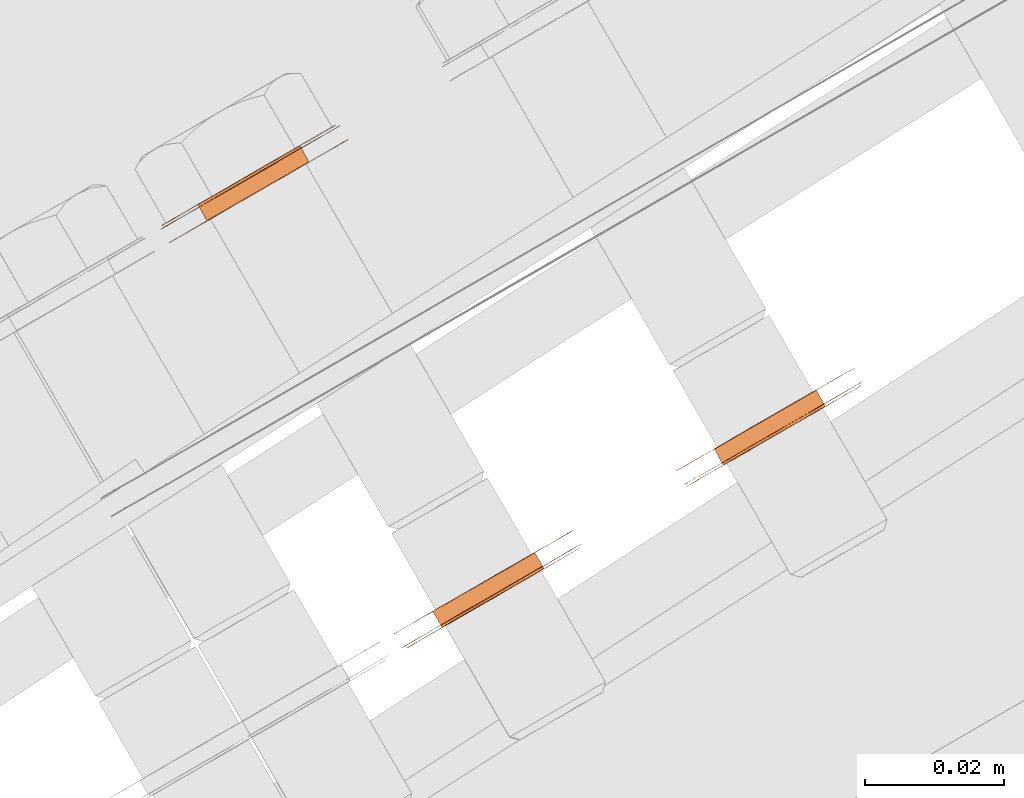
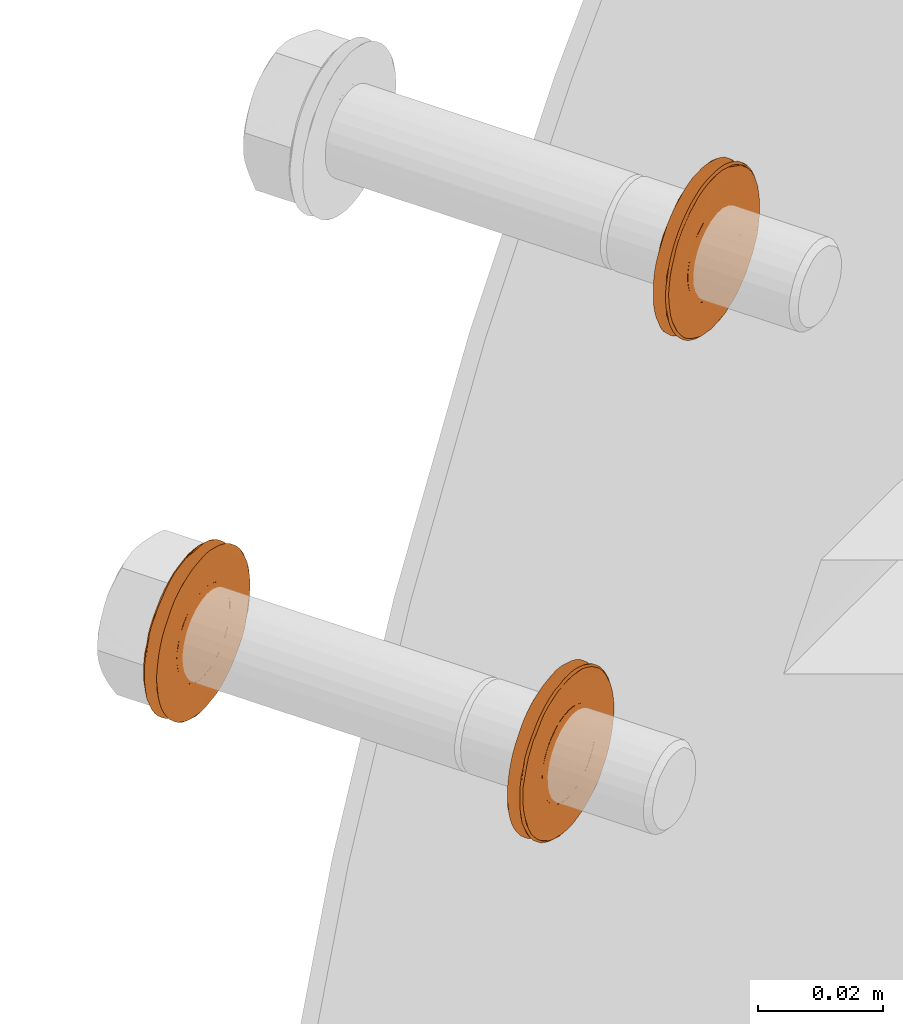
# One storey, part 106 of 126: 3 proxies.
"""IFC2X3 building model written with IfcOpenShell, lengths in millimetres."""

from ifc_helpers import new_model, si_unit, origin, origin_with_axes, place, context, project, spatial, faceted_brep, material, element, save


model = new_model("IFC2X3")

# Units and contexts
context_of_model_1 = context(None, 3, precision=0.1, world=origin())
context_of_model_2 = context(None, 3, precision=0.1, world=origin())
ifc_project = project(units=[si_unit("LENGTHUNIT", "METRE", prefix="MILLI"), si_unit("AREAUNIT", "SQUARE_METRE", prefix="CENTI"), si_unit("VOLUMEUNIT", "CUBIC_METRE", prefix="CENTI"), si_unit("MASSUNIT", "GRAM", prefix="KILO")], contexts=[context_of_model_1, context_of_model_2])

# Site, building, storey
site_placement = place(None, origin_with_axes())
site = spatial("IfcSite", under=ifc_project, at=site_placement, CompositionType="ELEMENT")
building_placement = place(site_placement, origin_with_axes())
building = spatial("IfcBuilding", under=site, at=building_placement, CompositionType="ELEMENT")
storey_placement = place(building_placement, origin_with_axes())
storey = spatial("IfcBuildingStorey", under=building, at=storey_placement, CompositionType="ELEMENT")

# Proxies
ifc_material = material(Name="STAHL")
proxy_1_placement = place(storey_placement, origin_with_axes())
element("IfcBuildingElementProxy", 1, at=proxy_1_placement, inside=storey, material=ifc_material, Name="profile", context=context_of_model_2, shape_type="Brep", body=[
    faceted_brep([(3695.3, 14720.1, 1091.5), (3693.9, 14722.4, 1091.5), (3693.0, 14721.9, 1090.9), (3694.4, 14719.6, 1090.9), (3696.2, 14720.6, 1092.2), (3694.8, 14722.9, 1092.2), (3696.9, 14721.0, 1093.0), (3695.6, 14723.4, 1093.0), (3697.6, 14721.4, 1094.0), (3696.2, 14723.7, 1094.0), (3684.8, 14714.0, 1102.4), (3683.4, 14716.4, 1102.4), (3684.0, 14716.7, 1103.4), (3685.3, 14714.3, 1103.4), (3684.4, 14713.8, 1101.2), (3683.1, 14716.2, 1101.2), (3684.2, 14713.7, 1100.1), (3682.8, 14716.0, 1100.1), (3684.1, 14713.6, 1098.9), (3682.7, 14716.0, 1098.9), (3684.1, 14713.7, 1097.6), (3682.8, 14716.0, 1097.6), (3684.3, 14713.8, 1096.5), (3683.0, 14716.1, 1096.5), (3684.7, 14714.0, 1095.3), (3683.3, 14716.3, 1095.3), (3685.2, 14714.3, 1094.2), (3683.8, 14716.6, 1094.2), (3685.8, 14714.6, 1093.2), (3684.4, 14716.9, 1093.2), (3686.5, 14715.0, 1092.4), (3685.2, 14717.4, 1092.4), (3687.3, 14715.5, 1091.6), (3686.0, 14717.8, 1091.6), (3688.3, 14716.0, 1091.0), (3686.9, 14718.4, 1091.0), (3689.2, 14716.6, 1090.6), (3687.9, 14718.9, 1090.6), (3690.3, 14717.2, 1090.3), (3688.9, 14719.5, 1090.3), (3691.3, 14717.8, 1090.2), (3689.9, 14720.1, 1090.2), (3692.3, 14718.4, 1090.3), (3691.0, 14720.7, 1090.3), (3693.4, 14719.0, 1090.5), (3692.0, 14721.3, 1090.5), (3678.3, 14710.7, 1098.1), (3678.3, 14710.7, 1099.7), (3678.4, 14710.8, 1101.2), (3678.7, 14711.0, 1102.8), (3679.2, 14711.2, 1104.3), (3679.7, 14711.6, 1105.7), (3680.4, 14712.0, 1107.0), (3681.2, 14712.4, 1108.3), (3682.2, 14713.0, 1109.4), (3683.2, 14713.6, 1110.5), (3684.3, 14714.2, 1111.4), (3685.5, 14714.9, 1112.2), (3686.7, 14715.6, 1112.8), (3688.0, 14716.4, 1113.2), (3689.4, 14717.1, 1113.5), (3690.7, 14717.9, 1113.7), (3692.1, 14718.7, 1113.7), (3693.4, 14719.5, 1113.5), (3694.8, 14720.3, 1113.1), (3696.0, 14721.0, 1112.6), (3697.3, 14721.7, 1112.0), (3698.4, 14722.4, 1111.2), (3699.5, 14723.0, 1110.2), (3700.5, 14723.6, 1109.2), (3701.4, 14724.1, 1108.0), (3702.2, 14724.6, 1106.7), (3702.9, 14724.9, 1105.3), (3703.4, 14725.3, 1103.9), (3703.8, 14725.5, 1102.4), (3704.1, 14725.6, 1100.9), (3704.2, 14725.7, 1099.3), (3704.2, 14725.7, 1097.7), (3704.0, 14725.6, 1096.2), (3703.7, 14725.4, 1094.6), (3703.3, 14725.2, 1093.1), (3702.7, 14724.9, 1091.7), (3702.0, 14724.5, 1090.4), (3701.2, 14724.0, 1089.1), (3700.3, 14723.4, 1088.0), (3699.3, 14722.9, 1086.9), (3698.2, 14722.2, 1086.0), (3697.0, 14721.5, 1085.2), (3695.7, 14720.8, 1084.6), (3694.4, 14720.1, 1084.2), (3693.1, 14719.3, 1083.9), (3691.7, 14718.5, 1083.7), (3690.6, 14720.5, 1083.7), (3691.9, 14721.3, 1083.9), (3693.3, 14722.1, 1084.2), (3694.6, 14722.8, 1084.6), (3695.8, 14723.5, 1085.2), (3697.0, 14724.2, 1086.0), (3698.1, 14724.9, 1086.9), (3699.1, 14725.4, 1088.0), (3700.1, 14726.0, 1089.1), (3700.9, 14726.4, 1090.4), (3701.6, 14726.8, 1091.7), (3702.1, 14727.2, 1093.1), (3702.6, 14727.4, 1094.6), (3702.9, 14727.6, 1096.2), (3703.0, 14727.7, 1097.7), (3703.1, 14727.7, 1099.3), (3702.9, 14727.6, 1100.9), (3702.7, 14727.5, 1102.4), (3702.3, 14727.2, 1103.9), (3701.7, 14726.9, 1105.3), (3701.1, 14726.6, 1106.7), (3700.3, 14726.1, 1108.0), (3699.4, 14725.6, 1109.2), (3698.4, 14725.0, 1110.2), (3697.3, 14724.4, 1111.2), (3696.1, 14723.7, 1112.0), (3694.9, 14723.0, 1112.6), (3693.6, 14722.2, 1113.1), (3692.3, 14721.5, 1113.5), (3690.9, 14720.7, 1113.7), (3689.6, 14719.9, 1113.7), (3688.2, 14719.1, 1113.5), (3686.9, 14718.4, 1113.2), (3685.6, 14717.6, 1112.8), (3684.3, 14716.9, 1112.2), (3683.1, 14716.2, 1111.4), (3682.0, 14715.6, 1110.5), (3681.0, 14715.0, 1109.4), (3680.1, 14714.4, 1108.3), (3679.3, 14714.0, 1107.0), (3678.6, 14713.6, 1105.7), (3678.0, 14713.2, 1104.3), (3677.6, 14713.0, 1102.8), (3677.3, 14712.8, 1101.2), (3677.1, 14712.7, 1099.7), (3677.1, 14712.7, 1098.1), (3677.2, 14712.8, 1096.5), (3677.5, 14712.9, 1095.0), (3677.9, 14713.2, 1093.5), (3678.4, 14713.5, 1092.1), (3679.1, 14713.9, 1090.7), (3679.9, 14714.3, 1089.4), (3680.8, 14714.8, 1088.2), (3681.8, 14715.4, 1087.2), (3682.9, 14716.0, 1086.2), (3684.0, 14716.7, 1085.4), (3685.3, 14717.4, 1084.8), (3686.6, 14718.2, 1084.3), (3687.9, 14718.9, 1083.9), (3689.2, 14719.7, 1083.7), (3690.4, 14717.7, 1083.7), (3689.0, 14716.9, 1083.9), (3687.7, 14716.2, 1084.3), (3686.4, 14715.4, 1084.8), (3685.2, 14714.7, 1085.4), (3684.0, 14714.0, 1086.2), (3682.9, 14713.4, 1087.2), (3681.9, 14712.8, 1088.2), (3681.0, 14712.3, 1089.4), (3680.2, 14711.9, 1090.7), (3679.6, 14711.5, 1092.1), (3679.0, 14711.2, 1093.5), (3678.6, 14710.9, 1095.0), (3678.4, 14710.8, 1096.5), (3678.8, 14710.6, 1099.4), (3678.9, 14710.7, 1101.0), (3679.2, 14710.8, 1102.5), (3679.7, 14711.1, 1104.0), (3680.2, 14711.4, 1105.5), (3680.9, 14711.8, 1106.8), (3681.7, 14712.3, 1108.1), (3682.7, 14712.8, 1109.2), (3683.7, 14713.4, 1110.3), (3684.8, 14714.1, 1111.2), (3686.0, 14714.8, 1111.9), (3687.3, 14715.5, 1112.5), (3688.6, 14716.3, 1112.9), (3690.0, 14717.0, 1113.2), (3691.3, 14717.8, 1113.3), (3692.7, 14718.6, 1113.2), (3694.1, 14719.4, 1113.0), (3695.4, 14720.2, 1112.6), (3696.7, 14720.9, 1112.0), (3697.9, 14721.6, 1111.3), (3699.0, 14722.2, 1110.4), (3700.1, 14722.9, 1109.4), (3701.0, 14723.4, 1108.2), (3701.8, 14723.9, 1107.0), (3702.6, 14724.3, 1105.6), (3703.1, 14724.6, 1104.2), (3703.6, 14724.9, 1102.7), (3703.9, 14725.1, 1101.2), (3704.1, 14725.2, 1099.6), (3704.1, 14725.2, 1098.0), (3703.9, 14725.1, 1096.4), (3703.6, 14724.9, 1094.9), (3703.2, 14724.7, 1093.4), (3702.6, 14724.3, 1091.9), (3701.9, 14723.9, 1090.6), (3701.1, 14723.5, 1089.3), (3700.2, 14722.9, 1088.2), (3699.2, 14722.3, 1087.1), (3698.0, 14721.7, 1086.2), (3696.8, 14721.0, 1085.5), (3695.5, 14720.2, 1084.9), (3694.2, 14719.5, 1084.5), (3692.9, 14718.7, 1084.2), (3691.5, 14717.9, 1084.1), (3690.1, 14717.1, 1084.2), (3688.8, 14716.3, 1084.4), (3687.5, 14715.6, 1084.8), (3686.2, 14714.8, 1085.4), (3685.0, 14714.1, 1086.1), (3683.8, 14713.5, 1087.0), (3682.8, 14712.9, 1088.0), (3681.8, 14712.3, 1089.2), (3681.0, 14711.9, 1090.4), (3680.3, 14711.4, 1091.8), (3679.7, 14711.1, 1093.2), (3679.3, 14710.8, 1094.7), (3679.0, 14710.7, 1096.2), (3678.8, 14710.6, 1097.8), (3698.7, 14722.1, 1099.8), (3698.8, 14722.1, 1098.5), (3698.7, 14722.1, 1097.3), (3698.5, 14721.9, 1096.2), (3698.1, 14721.7, 1095.0), (3686.0, 14714.7, 1104.4), (3686.7, 14715.1, 1105.2), (3687.6, 14715.6, 1105.9), (3688.5, 14716.2, 1106.5), (3689.5, 14716.7, 1106.9), (3690.5, 14717.3, 1107.1), (3691.6, 14717.9, 1107.2), (3692.6, 14718.5, 1107.1), (3693.6, 14719.1, 1106.8), (3694.6, 14719.7, 1106.4), (3695.5, 14720.2, 1105.8), (3696.3, 14720.7, 1105.0), (3697.1, 14721.1, 1104.2), (3697.7, 14721.5, 1103.2), (3698.2, 14721.8, 1102.1), (3698.5, 14722.0, 1100.9), (3686.2, 14718.0, 1105.9), (3687.1, 14718.5, 1106.5), (3685.4, 14717.5, 1105.2), (3684.6, 14717.0, 1104.4), (3696.7, 14724.0, 1095.0), (3697.1, 14724.3, 1096.2), (3697.3, 14724.4, 1097.3), (3697.4, 14724.5, 1098.5), (3697.4, 14724.4, 1099.8), (3697.2, 14724.3, 1100.9), (3696.8, 14724.1, 1102.1), (3696.3, 14723.8, 1103.2), (3695.7, 14723.5, 1104.2), (3695.0, 14723.0, 1105.0), (3694.2, 14722.6, 1105.8), (3693.3, 14722.0, 1106.4), (3692.3, 14721.5, 1106.8), (3691.3, 14720.9, 1107.1), (3690.2, 14720.3, 1107.2), (3689.2, 14719.7, 1107.1), (3688.1, 14719.1, 1106.9)], [[[0, 1, 2, 3]], [[4, 5, 1, 0]], [[6, 7, 5, 4]], [[6, 8, 9, 7]], [[10, 11, 12, 13]], [[14, 15, 11, 10]], [[16, 17, 15, 14]], [[18, 19, 17, 16]], [[20, 21, 19, 18]], [[22, 23, 21, 20]], [[24, 25, 23, 22]], [[26, 27, 25, 24]], [[28, 29, 27, 26]], [[30, 31, 29, 28]], [[32, 33, 31, 30]], [[34, 35, 33, 32]], [[36, 37, 35, 34]], [[38, 39, 37, 36]], [[40, 41, 39, 38]], [[42, 43, 41, 40]], [[44, 45, 43, 42]], [[3, 2, 45, 44]], [[46, 47, 48, 49, 50, 51, 52, 53, 54, 55, 56, 57, 58, 59, 60, 61, 62, 63, 64, 65, 66, 67, 68, 69, 70, 71, 72, 73, 74, 75, 76, 77, 78, 79, 80, 81, 82, 83, 84, 85, 86, 87, 88, 89, 90, 91, 92, 93, 94, 95, 96, 97, 98, 99, 100, 101, 102, 103, 104, 105, 106, 107, 108, 109, 110, 111, 112, 113, 114, 115, 116, 117, 118, 119, 120, 121, 122, 123, 124, 125, 126, 127, 128, 129, 130, 131, 132, 133, 134, 135, 136, 137, 138, 139, 140, 141, 142, 143, 144, 145, 146, 147, 148, 149, 150, 151, 92, 91, 152, 153, 154, 155, 156, 157, 158, 159, 160, 161, 162, 163, 164, 165]], [[166, 167, 168, 169, 170, 171, 172, 173, 174, 175, 176, 177, 178, 179, 180, 181, 182, 183, 184, 185, 186, 187, 188, 189, 190, 191, 192, 193, 75, 74, 73, 72, 71, 70, 69, 68, 67, 66, 65, 64, 63, 62, 61, 60, 59, 58, 57, 56, 55, 54, 53, 52, 51, 50, 49, 48, 47, 46, 165, 164, 163, 162, 161, 160, 159, 158, 157, 156, 155, 154, 153, 152, 91, 90, 89, 88, 87, 86, 85, 84, 83, 82, 81, 80, 79, 78, 77, 76, 75, 193, 194, 195, 196, 197, 198, 199, 200, 201, 202, 203, 204, 205, 206, 207, 208, 209, 210, 211, 212, 213, 214, 215, 216, 217, 218, 219, 220, 221, 222, 223]], [[166, 223, 222, 221, 220, 219, 218, 217, 216, 215, 214, 213, 212, 211, 210, 209, 208, 207, 206, 205, 204, 203, 202, 201, 200, 199, 198, 197, 196, 195, 194, 193, 224, 225, 226, 227, 228, 8, 6, 4, 0, 3, 44, 42, 40, 38, 36, 34, 32, 30, 28, 26, 24, 22, 20, 18, 16, 14, 10, 13, 229, 230, 231, 232, 233, 234, 235, 236, 237, 238, 239, 240, 241, 242, 243, 244, 224, 193, 192, 191, 190, 189, 188, 187, 186, 185, 184, 183, 182, 181, 180, 179, 178, 177, 176, 175, 174, 173, 172, 171, 170, 169, 168, 167]], [[231, 245, 246, 232]], [[230, 247, 245, 231]], [[229, 248, 247, 230]], [[228, 249, 9, 8]], [[13, 12, 248, 229]], [[227, 250, 249, 228]], [[226, 251, 250, 227]], [[225, 252, 251, 226]], [[224, 253, 252, 225]], [[244, 254, 253, 224]], [[243, 255, 254, 244]], [[242, 256, 255, 243]], [[241, 257, 256, 242]], [[240, 258, 257, 241]], [[239, 259, 258, 240]], [[238, 260, 259, 239]], [[237, 261, 260, 238]], [[236, 262, 261, 237]], [[235, 263, 262, 236]], [[234, 264, 263, 235]], [[233, 265, 264, 234]], [[232, 246, 265, 233]], [[137, 136, 135, 134, 133, 132, 131, 130, 129, 128, 127, 126, 125, 124, 123, 122, 121, 120, 119, 118, 117, 116, 115, 114, 113, 112, 111, 110, 109, 254, 255, 256, 257, 258, 259, 260, 261, 262, 263, 264, 265, 246, 245, 247, 248, 12, 11, 15, 17, 19, 21, 23, 25, 27, 29, 31, 33, 35, 37, 39, 41, 43, 45, 2, 1, 5, 7, 9, 249, 250, 251, 252, 253, 254, 109, 108, 107, 106, 105, 104, 103, 102, 101, 100, 99, 98, 97, 96, 95, 94, 93, 92, 151, 150, 149, 148, 147, 146, 145, 144, 143, 142, 141, 140, 139, 138]]]),
])
proxy_2_placement = place(storey_placement, origin_with_axes())
element("IfcBuildingElementProxy", 2, at=proxy_2_placement, inside=storey, material=ifc_material, Name="profile", context=context_of_model_2, shape_type="Brep", body=[
    faceted_brep([(3662.4, 14782.4, 1094.0), (3663.7, 14780.0, 1094.0), (3664.2, 14780.3, 1095.0), (3662.9, 14782.7, 1095.0), (3650.1, 14775.3, 1103.4), (3650.8, 14775.7, 1104.4), (3652.1, 14773.3, 1104.4), (3651.5, 14773.0, 1103.4), (3651.5, 14776.1, 1105.2), (3652.9, 14773.8, 1105.2), (3652.4, 14776.6, 1105.9), (3653.7, 14774.3, 1105.9), (3653.3, 14777.1, 1106.5), (3654.6, 14774.8, 1106.5), (3654.3, 14777.7, 1106.9), (3655.6, 14775.4, 1106.9), (3655.3, 14778.3, 1107.1), (3656.7, 14776.0, 1107.1), (3656.4, 14778.9, 1107.2), (3657.7, 14776.6, 1107.2), (3657.4, 14779.5, 1107.1), (3658.8, 14777.2, 1107.1), (3658.4, 14780.1, 1106.8), (3659.8, 14777.8, 1106.8), (3659.4, 14780.7, 1106.4), (3660.8, 14778.3, 1106.4), (3660.3, 14781.2, 1105.8), (3661.7, 14778.9, 1105.8), (3661.1, 14781.7, 1105.0), (3662.5, 14779.3, 1105.0), (3661.9, 14782.1, 1104.2), (3663.2, 14779.8, 1104.2), (3662.5, 14782.5, 1103.2), (3663.8, 14780.1, 1103.2), (3663.0, 14782.7, 1102.1), (3664.3, 14780.4, 1102.1), (3663.3, 14782.9, 1100.9), (3664.7, 14780.6, 1100.9), (3663.5, 14783.1, 1099.8), (3664.9, 14780.7, 1099.8), (3663.6, 14783.1, 1098.5), (3664.9, 14780.7, 1098.5), (3663.5, 14783.0, 1097.3), (3664.8, 14780.7, 1097.3), (3663.3, 14782.9, 1096.2), (3664.6, 14780.6, 1096.2), (3644.6, 14769.0, 1098.1), (3644.6, 14769.0, 1099.7), (3644.8, 14769.1, 1101.2), (3645.1, 14769.3, 1102.8), (3645.5, 14769.5, 1104.3), (3646.1, 14769.9, 1105.7), (3646.8, 14770.3, 1107.0), (3647.6, 14770.7, 1108.3), (3648.5, 14771.3, 1109.4), (3649.5, 14771.9, 1110.5), (3650.6, 14772.5, 1111.4), (3651.8, 14773.2, 1112.2), (3653.1, 14773.9, 1112.8), (3654.4, 14774.7, 1113.2), (3655.7, 14775.4, 1113.5), (3657.1, 14776.2, 1113.7), (3658.4, 14777.0, 1113.7), (3659.8, 14777.8, 1113.5), (3661.1, 14778.5, 1113.1), (3662.4, 14779.3, 1112.6), (3663.6, 14780.0, 1112.0), (3664.8, 14780.7, 1111.2), (3665.9, 14781.3, 1110.2), (3666.9, 14781.9, 1109.2), (3667.8, 14782.4, 1108.0), (3668.6, 14782.8, 1106.7), (3669.2, 14783.2, 1105.3), (3669.8, 14783.5, 1103.9), (3668.6, 14785.5, 1103.9), (3668.1, 14785.2, 1105.3), (3667.4, 14784.8, 1106.7), (3666.6, 14784.4, 1108.0), (3665.7, 14783.9, 1109.2), (3664.7, 14783.3, 1110.2), (3663.6, 14782.7, 1111.2), (3662.5, 14782.0, 1112.0), (3661.2, 14781.3, 1112.6), (3660.0, 14780.5, 1113.1), (3658.6, 14779.8, 1113.5), (3657.3, 14779.0, 1113.7), (3655.9, 14778.2, 1113.7), (3654.6, 14777.4, 1113.5), (3653.2, 14776.6, 1113.2), (3651.9, 14775.9, 1112.8), (3650.7, 14775.2, 1112.2), (3649.5, 14774.5, 1111.4), (3648.4, 14773.8, 1110.5), (3647.4, 14773.3, 1109.4), (3646.4, 14772.7, 1108.3), (3645.6, 14772.3, 1107.0), (3644.9, 14771.9, 1105.7), (3644.4, 14771.5, 1104.3), (3643.9, 14771.3, 1102.8), (3643.6, 14771.1, 1101.2), (3643.5, 14771.0, 1099.7), (3643.5, 14771.0, 1098.1), (3643.6, 14771.1, 1096.5), (3643.8, 14771.2, 1095.0), (3644.2, 14771.5, 1093.5), (3644.8, 14771.8, 1092.1), (3645.4, 14772.1, 1090.7), (3646.2, 14772.6, 1089.4), (3647.1, 14773.1, 1088.2), (3648.1, 14773.7, 1087.2), (3649.2, 14774.3, 1086.2), (3650.4, 14775.0, 1085.4), (3651.6, 14775.7, 1084.8), (3652.9, 14776.5, 1084.3), (3654.2, 14777.2, 1083.9), (3655.6, 14778.0, 1083.7), (3656.9, 14778.8, 1083.7), (3658.3, 14779.6, 1083.9), (3659.6, 14780.3, 1084.2), (3660.9, 14781.1, 1084.6), (3662.2, 14781.8, 1085.2), (3663.4, 14782.5, 1086.0), (3664.5, 14783.1, 1086.9), (3665.5, 14783.7, 1088.0), (3666.4, 14784.3, 1089.1), (3667.2, 14784.7, 1090.4), (3667.9, 14785.1, 1091.7), (3668.5, 14785.5, 1093.1), (3668.9, 14785.7, 1094.6), (3669.2, 14785.9, 1096.2), (3669.4, 14786.0, 1097.7), (3669.4, 14786.0, 1099.3), (3669.3, 14785.9, 1100.9), (3669.0, 14785.8, 1102.4), (3670.2, 14783.8, 1102.4), (3670.4, 14783.9, 1100.9), (3670.6, 14784.0, 1099.3), (3670.5, 14784.0, 1097.7), (3670.4, 14783.9, 1096.2), (3670.1, 14783.7, 1094.6), (3669.6, 14783.5, 1093.1), (3669.1, 14783.1, 1091.7), (3668.4, 14782.7, 1090.4), (3667.6, 14782.3, 1089.1), (3666.6, 14781.7, 1088.0), (3665.6, 14781.1, 1086.9), (3664.5, 14780.5, 1086.0), (3663.3, 14779.8, 1085.2), (3662.1, 14779.1, 1084.6), (3660.8, 14778.3, 1084.2), (3659.4, 14777.6, 1083.9), (3658.1, 14776.8, 1083.7), (3656.7, 14776.0, 1083.7), (3655.4, 14775.2, 1083.9), (3654.1, 14774.5, 1084.3), (3652.8, 14773.7, 1084.8), (3651.5, 14773.0, 1085.4), (3650.4, 14772.3, 1086.2), (3649.3, 14771.7, 1087.2), (3648.3, 14771.1, 1088.2), (3647.4, 14770.6, 1089.4), (3646.6, 14770.2, 1090.7), (3645.9, 14769.8, 1092.1), (3645.4, 14769.5, 1093.5), (3645.0, 14769.2, 1095.0), (3644.7, 14769.1, 1096.5), (3657.7, 14779.7, 1084.2), (3659.0, 14780.5, 1084.5), (3660.3, 14781.2, 1084.9), (3661.6, 14781.9, 1085.5), (3662.8, 14782.6, 1086.2), (3664.0, 14783.3, 1087.1), (3665.0, 14783.9, 1088.2), (3665.9, 14784.4, 1089.3), (3666.7, 14784.9, 1090.6), (3667.4, 14785.3, 1091.9), (3668.0, 14785.6, 1093.4), (3668.4, 14785.9, 1094.9), (3668.7, 14786.0, 1096.4), (3668.9, 14786.1, 1098.0), (3668.9, 14786.1, 1099.6), (3668.7, 14786.0, 1101.2), (3668.4, 14785.9, 1102.7), (3667.9, 14785.6, 1104.2), (3667.4, 14785.3, 1105.6), (3666.6, 14784.9, 1107.0), (3665.8, 14784.4, 1108.2), (3664.9, 14783.8, 1109.4), (3663.8, 14783.2, 1110.4), (3662.7, 14782.6, 1111.3), (3661.5, 14781.9, 1112.0), (3660.2, 14781.1, 1112.6), (3658.9, 14780.4, 1113.0), (3657.5, 14779.6, 1113.2), (3656.1, 14778.8, 1113.3), (3654.8, 14778.0, 1113.2), (3653.4, 14777.2, 1112.9), (3652.1, 14776.5, 1112.5), (3650.8, 14775.7, 1111.9), (3649.6, 14775.0, 1111.2), (3648.5, 14774.4, 1110.3), (3647.5, 14773.8, 1109.2), (3646.5, 14773.2, 1108.1), (3645.7, 14772.8, 1106.8), (3645.0, 14772.4, 1105.5), (3644.5, 14772.0, 1104.0), (3644.0, 14771.8, 1102.5), (3643.7, 14771.6, 1101.0), (3643.6, 14771.5, 1099.4), (3643.6, 14771.6, 1097.8), (3643.8, 14771.6, 1096.2), (3644.1, 14771.8, 1094.7), (3644.5, 14772.1, 1093.2), (3645.1, 14772.4, 1091.8), (3645.8, 14772.8, 1090.4), (3646.6, 14773.3, 1089.2), (3647.6, 14773.9, 1088.0), (3648.6, 14774.5, 1087.0), (3649.8, 14775.1, 1086.1), (3651.0, 14775.8, 1085.4), (3652.3, 14776.6, 1084.8), (3653.6, 14777.3, 1084.4), (3654.9, 14778.1, 1084.2), (3656.3, 14778.9, 1084.1), (3658.2, 14780.0, 1090.5), (3659.2, 14780.5, 1090.9), (3660.1, 14781.1, 1091.5), (3661.0, 14781.6, 1092.2), (3661.7, 14782.0, 1093.0), (3649.6, 14775.0, 1102.4), (3649.2, 14774.8, 1101.2), (3649.0, 14774.6, 1100.1), (3648.9, 14774.6, 1098.9), (3648.9, 14774.6, 1097.6), (3649.1, 14774.7, 1096.5), (3649.5, 14774.9, 1095.3), (3650.0, 14775.2, 1094.2), (3650.6, 14775.6, 1093.2), (3651.3, 14776.0, 1092.4), (3652.1, 14776.5, 1091.6), (3653.1, 14777.0, 1091.0), (3654.0, 14777.6, 1090.6), (3655.1, 14778.2, 1090.3), (3656.1, 14778.8, 1090.2), (3657.1, 14779.4, 1090.3), (3650.9, 14772.7, 1102.4), (3663.1, 14779.7, 1093.0), (3662.3, 14779.2, 1092.2), (3661.4, 14778.7, 1091.5), (3660.5, 14778.2, 1090.9), (3659.5, 14777.6, 1090.5), (3658.5, 14777.0, 1090.3), (3657.4, 14776.4, 1090.2), (3656.4, 14775.8, 1090.3), (3655.4, 14775.2, 1090.6), (3654.4, 14774.7, 1091.0), (3653.5, 14774.1, 1091.6), (3652.7, 14773.7, 1092.4), (3651.9, 14773.2, 1093.2), (3651.3, 14772.9, 1094.2), (3650.8, 14772.6, 1095.3), (3650.5, 14772.4, 1096.5), (3650.3, 14772.3, 1097.6), (3650.2, 14772.2, 1098.9), (3650.3, 14772.3, 1100.1), (3650.6, 14772.4, 1101.2)], [[[0, 1, 2, 3]], [[4, 5, 6, 7]], [[5, 8, 9, 6]], [[8, 10, 11, 9]], [[10, 12, 13, 11]], [[12, 14, 15, 13]], [[14, 16, 17, 15]], [[16, 18, 19, 17]], [[18, 20, 21, 19]], [[20, 22, 23, 21]], [[22, 24, 25, 23]], [[24, 26, 27, 25]], [[26, 28, 29, 27]], [[28, 30, 31, 29]], [[30, 32, 33, 31]], [[32, 34, 35, 33]], [[34, 36, 37, 35]], [[36, 38, 39, 37]], [[38, 40, 41, 39]], [[40, 42, 43, 41]], [[42, 44, 45, 43]], [[44, 3, 2, 45]], [[46, 47, 48, 49, 50, 51, 52, 53, 54, 55, 56, 57, 58, 59, 60, 61, 62, 63, 64, 65, 66, 67, 68, 69, 70, 71, 72, 73, 74, 75, 76, 77, 78, 79, 80, 81, 82, 83, 84, 85, 86, 87, 88, 89, 90, 91, 92, 93, 94, 95, 96, 97, 98, 99, 100, 101, 102, 103, 104, 105, 106, 107, 108, 109, 110, 111, 112, 113, 114, 115, 116, 117, 118, 119, 120, 121, 122, 123, 124, 125, 126, 127, 128, 129, 130, 131, 132, 133, 74, 73, 134, 135, 136, 137, 138, 139, 140, 141, 142, 143, 144, 145, 146, 147, 148, 149, 150, 151, 152, 153, 154, 155, 156, 157, 158, 159, 160, 161, 162, 163, 164, 165]], [[101, 100, 99, 98, 97, 96, 95, 94, 93, 92, 91, 90, 89, 88, 87, 86, 85, 84, 83, 82, 81, 80, 79, 78, 77, 76, 75, 74, 133, 132, 131, 130, 129, 128, 127, 126, 125, 124, 123, 122, 121, 120, 119, 118, 117, 166, 167, 168, 169, 170, 171, 172, 173, 174, 175, 176, 177, 178, 179, 180, 181, 182, 183, 184, 185, 186, 187, 188, 189, 190, 191, 192, 193, 194, 195, 196, 197, 198, 199, 200, 201, 202, 203, 204, 205, 206, 207, 208, 209, 210, 211, 212, 213, 214, 215, 216, 217, 218, 219, 220, 221, 222, 223, 166, 117, 116, 115, 114, 113, 112, 111, 110, 109, 108, 107, 106, 105, 104, 103, 102]], [[208, 207, 206, 205, 204, 203, 202, 201, 200, 199, 198, 197, 196, 195, 194, 193, 192, 191, 190, 189, 188, 187, 186, 185, 184, 183, 182, 181, 180, 179, 178, 177, 176, 175, 174, 173, 172, 171, 170, 169, 168, 167, 224, 225, 226, 227, 228, 0, 3, 44, 42, 40, 38, 36, 34, 32, 30, 28, 26, 24, 22, 20, 18, 16, 14, 12, 10, 8, 5, 4, 229, 230, 231, 232, 233, 234, 235, 236, 237, 238, 239, 240, 241, 242, 243, 244, 224, 167, 166, 223, 222, 221, 220, 219, 218, 217, 216, 215, 214, 213, 212, 211, 210, 209]], [[4, 7, 245, 229]], [[0, 228, 246, 1]], [[228, 227, 247, 246]], [[227, 226, 248, 247]], [[226, 225, 249, 248]], [[225, 224, 250, 249]], [[224, 244, 251, 250]], [[244, 243, 252, 251]], [[243, 242, 253, 252]], [[242, 241, 254, 253]], [[241, 240, 255, 254]], [[240, 239, 256, 255]], [[239, 238, 257, 256]], [[238, 237, 258, 257]], [[237, 236, 259, 258]], [[236, 235, 260, 259]], [[235, 234, 261, 260]], [[234, 233, 262, 261]], [[233, 232, 263, 262]], [[232, 231, 264, 263]], [[231, 230, 265, 264]], [[230, 229, 245, 265]], [[46, 165, 164, 163, 162, 161, 160, 159, 158, 157, 156, 155, 154, 153, 152, 151, 150, 149, 148, 250, 251, 252, 253, 254, 255, 256, 257, 258, 259, 260, 261, 262, 263, 264, 265, 245, 7, 6, 9, 11, 13, 15, 17, 19, 21, 23, 25, 27, 29, 31, 33, 35, 37, 39, 41, 43, 45, 2, 1, 246, 247, 248, 249, 250, 148, 147, 146, 145, 144, 143, 142, 141, 140, 139, 138, 137, 136, 135, 134, 73, 72, 71, 70, 69, 68, 67, 66, 65, 64, 63, 62, 61, 60, 59, 58, 57, 56, 55, 54, 53, 52, 51, 50, 49, 48, 47]]]),
])
proxy_3_placement = place(storey_placement, origin_with_axes())
element("IfcBuildingElementProxy", 3, at=proxy_3_placement, inside=storey, material=ifc_material, Name="profile", context=context_of_model_2, shape_type="Brep", body=[
    faceted_brep([(3737.2, 14744.3, 1162.8), (3735.8, 14746.6, 1162.8), (3735.0, 14746.2, 1162.0), (3736.4, 14743.8, 1162.0), (3726.8, 14738.3, 1174.8), (3726.1, 14737.9, 1173.9), (3724.7, 14740.2, 1173.9), (3725.4, 14740.6, 1174.8), (3725.5, 14737.6, 1172.9), (3724.2, 14739.9, 1172.9), (3725.1, 14737.3, 1171.8), (3723.7, 14739.6, 1171.8), (3724.8, 14737.1, 1170.6), (3723.4, 14739.5, 1170.6), (3724.6, 14737.0, 1169.4), (3723.3, 14739.4, 1169.4), (3724.6, 14737.0, 1168.2), (3723.3, 14739.4, 1168.2), (3724.8, 14737.1, 1167.0), (3723.4, 14739.5, 1167.0), (3725.1, 14737.3, 1165.8), (3723.7, 14739.6, 1165.8), (3725.5, 14737.6, 1164.7), (3724.2, 14739.9, 1164.7), (3726.1, 14737.9, 1163.7), (3724.7, 14740.2, 1163.7), (3726.8, 14738.3, 1162.8), (3725.4, 14740.6, 1162.8), (3727.6, 14738.7, 1162.0), (3726.2, 14741.1, 1162.0), (3728.5, 14739.2, 1161.3), (3727.1, 14741.6, 1161.3), (3729.4, 14739.8, 1160.8), (3728.1, 14742.1, 1160.8), (3730.4, 14740.4, 1160.5), (3729.1, 14742.7, 1160.5), (3731.5, 14741.0, 1160.3), (3730.1, 14743.3, 1160.3), (3732.5, 14741.6, 1160.3), (3731.2, 14743.9, 1160.3), (3733.6, 14742.2, 1160.5), (3732.2, 14744.5, 1160.5), (3734.6, 14742.8, 1160.8), (3733.2, 14745.1, 1160.8), (3735.5, 14743.3, 1161.3), (3734.2, 14745.7, 1161.3), (3718.8, 14734.1, 1168.0), (3718.8, 14734.1, 1169.6), (3719.0, 14734.2, 1171.1), (3719.2, 14734.4, 1172.7), (3719.7, 14734.6, 1174.2), (3720.2, 14734.9, 1175.6), (3720.9, 14735.3, 1177.0), (3721.7, 14735.8, 1178.2), (3722.6, 14736.3, 1179.4), (3723.6, 14736.9, 1180.4), (3724.7, 14737.5, 1181.4), (3725.9, 14738.2, 1182.2), (3727.1, 14738.9, 1182.8), (3728.4, 14739.7, 1183.3), (3729.8, 14740.5, 1183.6), (3731.1, 14741.2, 1183.8), (3732.5, 14742.0, 1183.8), (3733.8, 14742.8, 1183.6), (3735.2, 14743.6, 1183.3), (3736.4, 14744.3, 1182.8), (3737.7, 14745.0, 1182.2), (3738.9, 14745.7, 1181.4), (3740.0, 14746.4, 1180.4), (3741.0, 14746.9, 1179.4), (3741.9, 14747.5, 1178.2), (3742.7, 14747.9, 1177.0), (3743.4, 14748.3, 1175.6), (3743.9, 14748.6, 1174.2), (3744.3, 14748.9, 1172.7), (3744.6, 14749.0, 1171.1), (3744.8, 14749.1, 1169.6), (3744.8, 14749.1, 1168.0), (3744.6, 14749.0, 1166.4), (3744.3, 14748.9, 1164.9), (3743.9, 14748.6, 1163.4), (3743.4, 14748.3, 1162.0), (3742.7, 14747.9, 1160.6), (3741.9, 14747.5, 1159.3), (3741.0, 14746.9, 1158.2), (3740.0, 14746.4, 1157.1), (3738.9, 14745.7, 1156.2), (3737.7, 14745.0, 1155.4), (3736.4, 14744.3, 1154.8), (3735.2, 14743.6, 1154.3), (3733.8, 14742.8, 1154.0), (3732.5, 14742.0, 1153.8), (3731.1, 14741.2, 1153.8), (3729.8, 14740.5, 1154.0), (3728.6, 14742.5, 1154.0), (3730.0, 14743.2, 1153.8), (3731.3, 14744.0, 1153.8), (3732.7, 14744.8, 1154.0), (3734.0, 14745.6, 1154.3), (3735.3, 14746.3, 1154.8), (3736.5, 14747.0, 1155.4), (3737.7, 14747.7, 1156.2), (3738.8, 14748.3, 1157.1), (3739.8, 14748.9, 1158.2), (3740.7, 14749.5, 1159.3), (3741.5, 14749.9, 1160.6), (3742.2, 14750.3, 1162.0), (3742.8, 14750.6, 1163.4), (3743.2, 14750.9, 1164.9), (3743.5, 14751.0, 1166.4), (3743.6, 14751.1, 1168.0), (3743.6, 14751.1, 1169.6), (3743.5, 14751.0, 1171.1), (3743.2, 14750.9, 1172.7), (3742.8, 14750.6, 1174.2), (3742.2, 14750.3, 1175.6), (3741.5, 14749.9, 1177.0), (3740.7, 14749.5, 1178.2), (3739.8, 14748.9, 1179.4), (3738.8, 14748.3, 1180.4), (3737.7, 14747.7, 1181.4), (3736.5, 14747.0, 1182.2), (3735.3, 14746.3, 1182.8), (3734.0, 14745.6, 1183.3), (3732.7, 14744.8, 1183.6), (3731.3, 14744.0, 1183.8), (3730.0, 14743.2, 1183.8), (3728.6, 14742.5, 1183.6), (3727.3, 14741.7, 1183.3), (3726.0, 14740.9, 1182.8), (3724.7, 14740.2, 1182.2), (3723.6, 14739.5, 1181.4), (3722.5, 14738.9, 1180.4), (3721.5, 14738.3, 1179.4), (3720.5, 14737.8, 1178.2), (3719.7, 14737.3, 1177.0), (3719.1, 14736.9, 1175.6), (3718.5, 14736.6, 1174.2), (3718.1, 14736.4, 1172.7), (3717.8, 14736.2, 1171.1), (3717.7, 14736.1, 1169.6), (3717.7, 14736.1, 1168.0), (3717.8, 14736.2, 1166.4), (3718.1, 14736.4, 1164.9), (3718.5, 14736.6, 1163.4), (3719.1, 14736.9, 1162.0), (3719.7, 14737.3, 1160.6), (3720.5, 14737.8, 1159.3), (3721.5, 14738.3, 1158.2), (3722.5, 14738.9, 1157.1), (3723.6, 14739.5, 1156.2), (3724.7, 14740.2, 1155.4), (3726.0, 14740.9, 1154.8), (3727.3, 14741.7, 1154.3), (3728.4, 14739.7, 1154.3), (3727.1, 14738.9, 1154.8), (3725.9, 14738.2, 1155.4), (3724.7, 14737.5, 1156.2), (3723.6, 14736.9, 1157.1), (3722.6, 14736.3, 1158.2), (3721.7, 14735.8, 1159.3), (3720.9, 14735.3, 1160.6), (3720.2, 14734.9, 1162.0), (3719.7, 14734.6, 1163.4), (3719.2, 14734.4, 1164.9), (3719.0, 14734.2, 1166.4), (3719.3, 14734.0, 1169.2), (3719.5, 14734.1, 1170.8), (3719.7, 14734.2, 1172.3), (3720.1, 14734.4, 1173.8), (3720.7, 14734.7, 1175.3), (3721.3, 14735.1, 1176.7), (3722.1, 14735.6, 1177.9), (3723.0, 14736.1, 1179.1), (3724.1, 14736.7, 1180.2), (3725.2, 14737.4, 1181.1), (3726.4, 14738.0, 1181.9), (3727.6, 14738.8, 1182.5), (3728.9, 14739.5, 1183.0), (3730.3, 14740.3, 1183.3), (3731.6, 14741.1, 1183.4), (3733.0, 14741.9, 1183.3), (3734.4, 14742.7, 1183.1), (3735.7, 14743.4, 1182.7), (3737.0, 14744.2, 1182.2), (3738.2, 14744.9, 1181.5), (3739.4, 14745.5, 1180.6), (3740.4, 14746.2, 1179.7), (3741.4, 14746.7, 1178.5), (3742.3, 14747.2, 1177.3), (3743.0, 14747.6, 1176.0), (3743.6, 14748.0, 1174.6), (3744.1, 14748.3, 1173.1), (3744.4, 14748.5, 1171.5), (3744.6, 14748.6, 1170.0), (3744.6, 14748.6, 1168.4), (3744.5, 14748.5, 1166.8), (3744.3, 14748.4, 1165.3), (3743.9, 14748.1, 1163.8), (3743.3, 14747.8, 1162.3), (3742.6, 14747.4, 1160.9), (3741.8, 14747.0, 1159.6), (3740.9, 14746.4, 1158.5), (3739.9, 14745.9, 1157.4), (3738.8, 14745.2, 1156.5), (3737.6, 14744.5, 1155.7), (3736.3, 14743.8, 1155.1), (3735.0, 14743.0, 1154.6), (3733.7, 14742.3, 1154.3), (3732.3, 14741.5, 1154.2), (3731.0, 14740.7, 1154.2), (3729.6, 14739.9, 1154.5), (3728.3, 14739.1, 1154.8), (3727.0, 14738.4, 1155.4), (3725.8, 14737.7, 1156.1), (3724.6, 14737.0, 1156.9), (3723.5, 14736.4, 1157.9), (3722.6, 14735.9, 1159.0), (3721.7, 14735.4, 1160.3), (3721.0, 14734.9, 1161.6), (3720.4, 14734.6, 1163.0), (3719.9, 14734.3, 1164.5), (3719.6, 14734.1, 1166.0), (3719.4, 14734.0, 1167.6), (3739.3, 14745.5, 1168.2), (3739.2, 14745.4, 1167.0), (3738.9, 14745.3, 1165.8), (3738.4, 14745.0, 1164.7), (3737.9, 14744.7, 1163.7), (3727.6, 14738.7, 1175.6), (3728.5, 14739.2, 1176.2), (3729.4, 14739.8, 1176.8), (3730.4, 14740.4, 1177.1), (3731.5, 14741.0, 1177.3), (3732.5, 14741.6, 1177.3), (3733.6, 14742.2, 1177.1), (3734.6, 14742.8, 1176.8), (3735.5, 14743.3, 1176.2), (3736.4, 14743.8, 1175.6), (3737.2, 14744.3, 1174.8), (3737.9, 14744.7, 1173.9), (3738.4, 14745.0, 1172.9), (3738.9, 14745.3, 1171.8), (3739.2, 14745.4, 1170.6), (3739.3, 14745.5, 1169.4), (3726.2, 14741.1, 1175.6), (3736.5, 14747.0, 1163.7), (3737.1, 14747.4, 1164.7), (3737.5, 14747.6, 1165.8), (3737.8, 14747.8, 1167.0), (3738.0, 14747.9, 1168.2), (3738.0, 14747.9, 1169.4), (3737.8, 14747.8, 1170.6), (3737.5, 14747.6, 1171.8), (3737.1, 14747.4, 1172.9), (3736.5, 14747.0, 1173.9), (3735.8, 14746.6, 1174.8), (3735.0, 14746.2, 1175.6), (3734.2, 14745.7, 1176.2), (3733.2, 14745.1, 1176.8), (3732.2, 14744.5, 1177.1), (3731.2, 14743.9, 1177.3), (3730.1, 14743.3, 1177.3), (3729.1, 14742.7, 1177.1), (3728.1, 14742.1, 1176.8), (3727.1, 14741.6, 1176.2)], [[[0, 1, 2, 3]], [[4, 5, 6, 7]], [[5, 8, 9, 6]], [[8, 10, 11, 9]], [[10, 12, 13, 11]], [[12, 14, 15, 13]], [[14, 16, 17, 15]], [[16, 18, 19, 17]], [[18, 20, 21, 19]], [[20, 22, 23, 21]], [[22, 24, 25, 23]], [[24, 26, 27, 25]], [[26, 28, 29, 27]], [[28, 30, 31, 29]], [[30, 32, 33, 31]], [[32, 34, 35, 33]], [[34, 36, 37, 35]], [[36, 38, 39, 37]], [[38, 40, 41, 39]], [[40, 42, 43, 41]], [[42, 44, 45, 43]], [[44, 3, 2, 45]], [[46, 47, 48, 49, 50, 51, 52, 53, 54, 55, 56, 57, 58, 59, 60, 61, 62, 63, 64, 65, 66, 67, 68, 69, 70, 71, 72, 73, 74, 75, 76, 77, 78, 79, 80, 81, 82, 83, 84, 85, 86, 87, 88, 89, 90, 91, 92, 93, 94, 95, 96, 97, 98, 99, 100, 101, 102, 103, 104, 105, 106, 107, 108, 109, 110, 111, 112, 113, 114, 115, 116, 117, 118, 119, 120, 121, 122, 123, 124, 125, 126, 127, 128, 129, 130, 131, 132, 133, 134, 135, 136, 137, 138, 139, 140, 141, 142, 143, 144, 145, 146, 147, 148, 149, 150, 151, 152, 153, 94, 93, 154, 155, 156, 157, 158, 159, 160, 161, 162, 163, 164, 165]], [[166, 167, 168, 169, 170, 171, 172, 173, 174, 175, 176, 177, 178, 179, 180, 181, 182, 183, 184, 185, 186, 187, 188, 189, 190, 191, 192, 193, 194, 76, 75, 74, 73, 72, 71, 70, 69, 68, 67, 66, 65, 64, 63, 62, 61, 60, 59, 58, 57, 56, 55, 54, 53, 52, 51, 50, 49, 48, 47, 46, 165, 164, 163, 162, 161, 160, 159, 158, 157, 156, 155, 154, 93, 92, 91, 90, 89, 88, 87, 86, 85, 84, 83, 82, 81, 80, 79, 78, 77, 76, 194, 195, 196, 197, 198, 199, 200, 201, 202, 203, 204, 205, 206, 207, 208, 209, 210, 211, 212, 213, 214, 215, 216, 217, 218, 219, 220, 221, 222, 223]], [[166, 223, 222, 221, 220, 219, 218, 217, 216, 215, 214, 213, 212, 211, 210, 209, 208, 207, 206, 205, 204, 203, 202, 201, 200, 199, 198, 197, 196, 195, 224, 225, 226, 227, 228, 0, 3, 44, 42, 40, 38, 36, 34, 32, 30, 28, 26, 24, 22, 20, 18, 16, 14, 12, 10, 8, 5, 4, 229, 230, 231, 232, 233, 234, 235, 236, 237, 238, 239, 240, 241, 242, 243, 244, 224, 195, 194, 193, 192, 191, 190, 189, 188, 187, 186, 185, 184, 183, 182, 181, 180, 179, 178, 177, 176, 175, 174, 173, 172, 171, 170, 169, 168, 167]], [[4, 7, 245, 229]], [[0, 228, 246, 1]], [[228, 227, 247, 246]], [[227, 226, 248, 247]], [[226, 225, 249, 248]], [[225, 224, 250, 249]], [[224, 244, 251, 250]], [[244, 243, 252, 251]], [[243, 242, 253, 252]], [[242, 241, 254, 253]], [[241, 240, 255, 254]], [[240, 239, 256, 255]], [[239, 238, 257, 256]], [[238, 237, 258, 257]], [[237, 236, 259, 258]], [[236, 235, 260, 259]], [[235, 234, 261, 260]], [[234, 233, 262, 261]], [[233, 232, 263, 262]], [[232, 231, 264, 263]], [[231, 230, 265, 264]], [[230, 229, 245, 265]], [[141, 140, 139, 138, 137, 136, 135, 134, 133, 132, 131, 130, 129, 128, 127, 126, 125, 124, 123, 122, 121, 120, 119, 118, 117, 116, 115, 114, 113, 112, 111, 110, 251, 252, 253, 254, 255, 256, 257, 258, 259, 260, 261, 262, 263, 264, 265, 245, 7, 6, 9, 11, 13, 15, 17, 19, 21, 23, 25, 27, 29, 31, 33, 35, 37, 39, 41, 43, 45, 2, 1, 246, 247, 248, 249, 250, 251, 110, 109, 108, 107, 106, 105, 104, 103, 102, 101, 100, 99, 98, 97, 96, 95, 94, 153, 152, 151, 150, 149, 148, 147, 146, 145, 144, 143, 142]]]),
])

save(model, "model.ifc")
